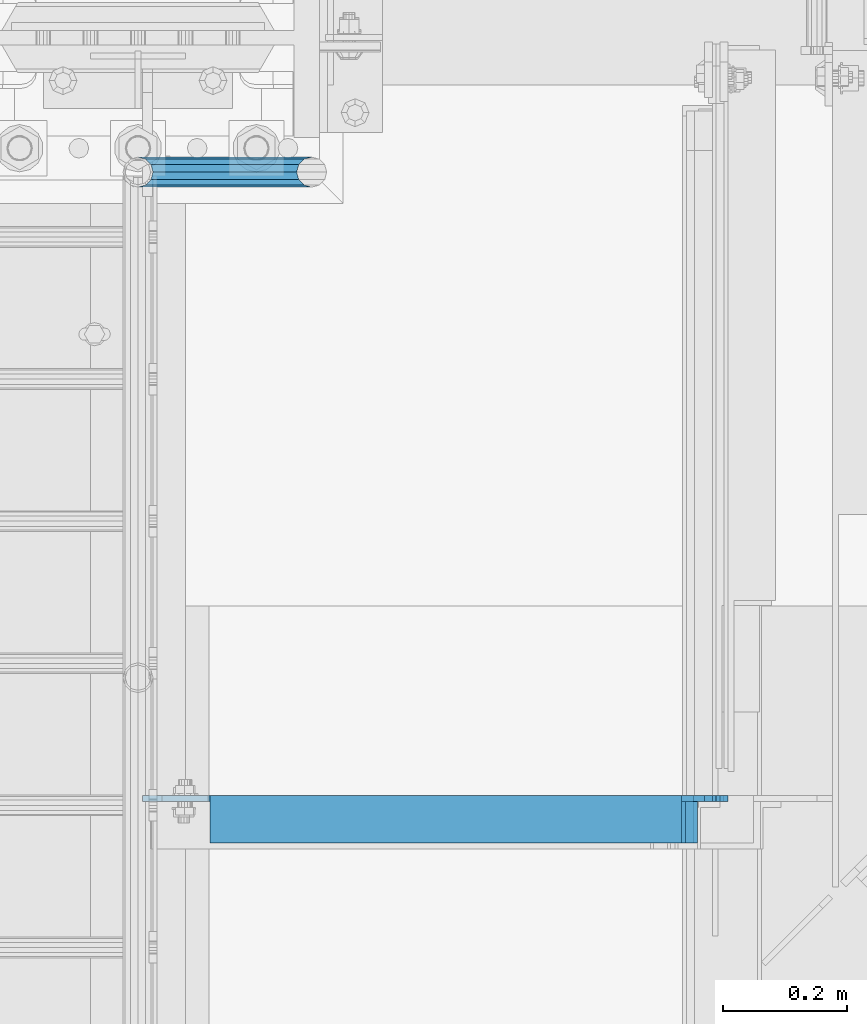
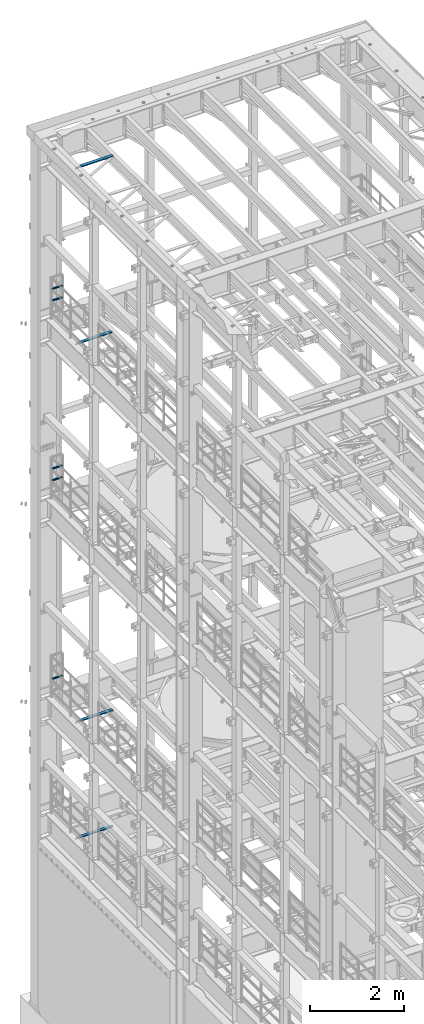
# One storey, part 1313 of 1876: 9 beams, 7 elements without a shape of their own.
"""IFC2X3 building model written with IfcOpenShell, lengths in millimetres."""

from ifc_helpers import new_model, si_unit, frame, origin_with_axes, place, context, subcontext, project, spatial, faceted_brep, material, type_object, element, aggregate, save


model = new_model("IFC2X3")

# Units and contexts
model_context = context("Model", 3, precision=1e-05, world=origin_with_axes())
body_context = subcontext(model_context, "Body", "Model", "MODEL_VIEW")
ifc_project = project(units=[si_unit("LENGTHUNIT", "METRE", prefix="MILLI"), si_unit("AREAUNIT", "SQUARE_METRE"), si_unit("VOLUMEUNIT", "CUBIC_METRE"), si_unit("MASSUNIT", "GRAM", prefix="KILO"), si_unit("TIMEUNIT", "SECOND"), si_unit("PLANEANGLEUNIT", "RADIAN"), si_unit("SOLIDANGLEUNIT", "STERADIAN"), si_unit("THERMODYNAMICTEMPERATUREUNIT", "DEGREE_CELSIUS"), si_unit("LUMINOUSINTENSITYUNIT", "LUMEN")], contexts=[model_context])

# Site, building, storey
site_placement = place(None, origin_with_axes())
site = spatial("IfcSite", under=ifc_project, at=site_placement, CompositionType="ELEMENT")
building_placement = place(site_placement, origin_with_axes())
building = spatial("IfcBuilding", under=site, at=building_placement, Name="Undefined", CompositionType="ELEMENT")
storey_placement = place(building_placement, origin_with_axes())
storey = spatial("IfcBuildingStorey", under=building, at=storey_placement, Name="Undefined", CompositionType="ELEMENT", Elevation=0.0)

# Assembly, beams
assembly_1_placement = place(storey_placement, origin_with_axes())
assembly_1 = element("IfcElementAssembly", 1, at=assembly_1_placement, inside=storey, Name="RAIL", AssemblyPlace="NOTDEFINED", PredefinedType="RIGID_FRAME")
ifc_material_1 = material()
beam_type_1 = type_object("IfcBeamType", Name="PIPE1-1/2SCH40", PredefinedType="NOTDEFINED")
beam_1_placement = place(assembly_1_placement, frame((-8.18545231595635e-12, 13499.7063, 18449.925000036), z_axis=(0.0, 0.0, 1.0), x_axis=(1.0, 0.0, 0.0)))
beam_1 = element("IfcBeam", 2, at=beam_1_placement, type_object=beam_type_1, material=ifc_material_1, Name="RAIL", ObjectType="PIPE1-1/2SCH40", context=body_context, shape_type="Brep", body=[
    faceted_brep([(258.502800903171, -12.0650000000005, 20.8971929933177), (258.502800903171, -12.0650000000005, 15.8661214311796), (258.009372465309, -10.2235000000001, 17.7076214311819), (255.26999389649, 0.0, 20.4470000000001), (255.26999389649, 0.0, 24.130000000001), (258.009372465309, 10.2235000000001, 17.7076214311819), (258.502800903171, 12.0650000000005, 15.8661214311796), (258.502800903171, 12.0650000000005, 20.8971929933177), (279.399993896489, 24.1299999999992, 0.0), (267.33499389649, 20.8971929933177, 12.0649999999987), (267.33499389649, 20.8971929933177, -12.0649999999987), (264.145422334351, 17.7076214311801, 10.2235000000001), (266.884800903171, 20.4470000000001, 0.0), (264.145422334351, 17.7076214311801, -10.2235000000001), (258.502800903171, 12.0650000000005, -15.8661214311796), (258.502800903171, 12.0650000000005, -20.8971929933177), (258.009372465309, 10.2235000000001, -17.7076214311819), (255.26999389649, 0.0, -20.4470000000001), (255.26999389649, 0.0, -24.130000000001), (258.502800903171, -12.0650000000005, -15.8661214311796), (258.502800903171, -12.0650000000005, -20.8971929933177), (258.009372465309, -10.2235000000001, -17.7076214311819), (279.399993896489, -24.1299999999992, 0.0), (267.33499389649, -20.8971929933177, -12.0649999999987), (267.33499389649, -20.8971929933177, 12.0649999999987), (264.145422334351, -17.7076214311801, -10.2235000000001), (266.884800903171, -20.4470000000001, 0.0), (264.145422334351, -17.7076214311801, 10.2235000000001), (12.0650000000064, -20.8971929933177, -12.0649999999987), (20.8971929933249, -12.0650000000005, -20.8971929933177), (0.0, 24.1299999999992, 0.0), (12.0650000000064, 20.8971929933177, -12.0649999999987), (12.0650000000064, 20.8971929933177, 12.0649999999987), (20.8971929933249, 12.0650000000005, 20.8971929933177), (24.1300000000064, 0.0, 24.130000000001), (20.8971929933249, 12.0650000000005, -20.8971929933177), (24.1300000000063, 0.0, -24.130000000001), (24.1300000000063, 0.0, -20.4470000000001), (20.8971929933249, -12.0650000000005, -15.8661214311796), (21.3906214311868, -10.2235000000001, -17.7076214311819), (21.3906214311868, 10.2235000000001, -17.7076214311819), (20.8971929933249, 12.0650000000005, -15.8661214311796), (15.2545715621445, 17.7076214311801, -10.2235000000001), (12.5151929933249, 20.4470000000001, 0.0), (15.2545715621445, 17.7076214311801, 10.2235000000001), (20.8971929933249, 12.0650000000005, 15.8661214311796), (21.3906214311868, 10.2235000000001, 17.7076214311819), (24.1300000000064, 0.0, 20.4470000000001), (21.3906214311868, -10.2235000000001, 17.7076214311819), (20.8971929933249, -12.0650000000005, 15.8661214311796), (20.8971929933249, -12.0650000000005, 20.8971929933177), (12.0650000000064, -20.8971929933177, 12.0649999999987), (0.0, -24.1299999999992, 0.0), (15.2545715621445, -17.7076214311801, 10.2235000000001), (12.5151929933249, -20.4470000000001, 0.0), (15.2545715621445, -17.7076214311801, -10.2235000000001)], [[[0, 1, 2, 3, 4]], [[4, 3, 5, 6, 7]], [[8, 9, 10]], [[7, 6, 11, 12, 13, 14, 15, 10, 9]], [[16, 17, 18, 15, 14]], [[19, 20, 18, 17, 21]], [[22, 23, 24]], [[24, 23, 20, 19, 25, 26, 27, 1, 0]], [[28, 29, 20, 23]], [[30, 31, 32]], [[33, 34, 4, 7]], [[32, 33, 7, 9]], [[30, 32, 9, 8]], [[31, 30, 8, 10]], [[35, 31, 10, 15]], [[36, 35, 15, 18]], [[29, 36, 18, 20]], [[37, 36, 29, 38, 39]], [[40, 41, 35, 36, 37]], [[32, 31, 35, 41, 42, 43, 44, 45, 33]], [[33, 45, 46, 47, 34]], [[34, 47, 48, 49, 50]], [[34, 50, 0, 4]], [[50, 51, 24, 0]], [[51, 52, 22, 24]], [[52, 28, 23, 22]], [[51, 28, 52]], [[50, 49, 53, 54, 55, 38, 29, 28, 51]], [[55, 54, 26, 25]], [[21, 39, 38, 55, 25, 19]], [[37, 39, 21, 17]], [[40, 37, 17, 16]], [[42, 41, 40, 16, 14, 13]], [[43, 42, 13, 12]], [[44, 43, 12, 11]], [[5, 46, 45, 44, 11, 6]], [[47, 46, 5, 3]], [[48, 47, 3, 2]], [[53, 49, 48, 2, 1, 27]], [[54, 53, 27, 26]]]),
])
beam_2_placement = place(assembly_1_placement, frame((-8.18545231595635e-12, 13499.7063, 18754.7250000359), z_axis=(0.0, 0.0, 1.0), x_axis=(1.0, 0.0, 0.0)))
beam_2 = element("IfcBeam", 3, at=beam_2_placement, type_object=beam_type_1, material=ifc_material_1, Name="RAIL", ObjectType="PIPE1-1/2SCH40", context=body_context, shape_type="Brep", body=[
    faceted_brep([(258.502800903171, -12.0650000000005, 20.8971929933177), (258.502800903171, -12.0650000000005, 15.8661214311796), (258.009372465309, -10.2235000000001, 17.7076214311819), (255.26999389649, 0.0, 20.4470000000001), (255.26999389649, 0.0, 24.130000000001), (258.009372465309, 10.2235000000001, 17.7076214311819), (258.502800903171, 12.0650000000005, 15.8661214311796), (258.502800903171, 12.0650000000005, 20.8971929933177), (279.399993896489, 24.1299999999992, 0.0), (267.33499389649, 20.8971929933177, 12.0649999999987), (267.33499389649, 20.8971929933177, -12.0649999999987), (264.145422334351, 17.7076214311801, 10.2235000000001), (266.884800903171, 20.4470000000001, 0.0), (264.145422334351, 17.7076214311801, -10.2235000000001), (258.502800903171, 12.0650000000005, -15.8661214311796), (258.502800903171, 12.0650000000005, -20.8971929933177), (258.009372465309, 10.2235000000001, -17.7076214311819), (255.26999389649, 0.0, -20.4470000000001), (255.26999389649, 0.0, -24.130000000001), (258.502800903171, -12.0650000000005, -15.8661214311796), (258.502800903171, -12.0650000000005, -20.8971929933177), (258.009372465309, -10.2235000000001, -17.7076214311819), (279.399993896489, -24.1299999999992, 0.0), (267.33499389649, -20.8971929933177, -12.0649999999987), (267.33499389649, -20.8971929933177, 12.0649999999987), (264.145422334351, -17.7076214311801, -10.2235000000001), (266.884800903171, -20.4470000000001, 0.0), (264.145422334351, -17.7076214311801, 10.2235000000001), (12.0650000000064, -20.8971929933177, -12.0649999999987), (20.8971929933249, -12.0650000000005, -20.8971929933177), (0.0, 24.1299999999992, 0.0), (12.0650000000064, 20.8971929933177, -12.0649999999987), (12.0650000000064, 20.8971929933177, 12.0649999999987), (20.8971929933249, 12.0650000000005, 20.8971929933177), (24.1300000000064, 0.0, 24.130000000001), (20.8971929933249, 12.0650000000005, -20.8971929933177), (24.1300000000063, 0.0, -24.130000000001), (24.1300000000063, 0.0, -20.4470000000001), (20.8971929933249, -12.0650000000005, -15.8661214311796), (21.3906214311868, -10.2235000000001, -17.7076214311819), (21.3906214311868, 10.2235000000001, -17.7076214311819), (20.8971929933249, 12.0650000000005, -15.8661214311796), (15.2545715621445, 17.7076214311801, -10.2235000000001), (12.5151929933249, 20.4470000000001, 0.0), (15.2545715621445, 17.7076214311801, 10.2235000000001), (20.8971929933249, 12.0650000000005, 15.8661214311796), (21.3906214311868, 10.2235000000001, 17.7076214311819), (24.1300000000064, 0.0, 20.4470000000001), (21.3906214311868, -10.2235000000001, 17.7076214311819), (20.8971929933249, -12.0650000000005, 15.8661214311796), (20.8971929933249, -12.0650000000005, 20.8971929933177), (12.0650000000064, -20.8971929933177, 12.0649999999987), (0.0, -24.1299999999992, 0.0), (15.2545715621445, -17.7076214311801, 10.2235000000001), (12.5151929933249, -20.4470000000001, 0.0), (15.2545715621445, -17.7076214311801, -10.2235000000001)], [[[0, 1, 2, 3, 4]], [[4, 3, 5, 6, 7]], [[8, 9, 10]], [[7, 6, 11, 12, 13, 14, 15, 10, 9]], [[16, 17, 18, 15, 14]], [[19, 20, 18, 17, 21]], [[22, 23, 24]], [[24, 23, 20, 19, 25, 26, 27, 1, 0]], [[28, 29, 20, 23]], [[30, 31, 32]], [[33, 34, 4, 7]], [[32, 33, 7, 9]], [[30, 32, 9, 8]], [[31, 30, 8, 10]], [[35, 31, 10, 15]], [[36, 35, 15, 18]], [[29, 36, 18, 20]], [[37, 36, 29, 38, 39]], [[40, 41, 35, 36, 37]], [[32, 31, 35, 41, 42, 43, 44, 45, 33]], [[33, 45, 46, 47, 34]], [[34, 47, 48, 49, 50]], [[34, 50, 0, 4]], [[50, 51, 24, 0]], [[51, 52, 22, 24]], [[52, 28, 23, 22]], [[51, 28, 52]], [[50, 49, 53, 54, 55, 38, 29, 28, 51]], [[55, 54, 26, 25]], [[21, 39, 38, 55, 25, 19]], [[37, 39, 21, 17]], [[40, 37, 17, 16]], [[42, 41, 40, 16, 14, 13]], [[43, 42, 13, 12]], [[44, 43, 12, 11]], [[5, 46, 45, 44, 11, 6]], [[47, 46, 5, 3]], [[48, 47, 3, 2]], [[53, 49, 48, 2, 1, 27]], [[54, 53, 27, 26]]]),
])
aggregate(assembly_1, [beam_1, beam_2])

assembly_2_placement = place(storey_placement, origin_with_axes())
assembly_2 = element("IfcElementAssembly", 4, at=assembly_2_placement, inside=storey, Name="RAIL", AssemblyPlace="NOTDEFINED", PredefinedType="RIGID_FRAME")
beam_3_placement = place(assembly_2_placement, frame((-8.18545231595635e-12, 13499.7063, 13776.325000036), z_axis=(0.0, 0.0, 1.0), x_axis=(1.0, 0.0, 0.0)))
beam_3 = element("IfcBeam", 5, at=beam_3_placement, type_object=beam_type_1, material=ifc_material_1, Name="RAIL", ObjectType="PIPE1-1/2SCH40", context=body_context, shape_type="Brep", body=[
    faceted_brep([(258.502800903171, -12.0650000000005, 20.8971929933177), (258.502800903171, -12.0650000000005, 15.8661214311796), (258.009372465309, -10.2235000000001, 17.7076214311819), (255.26999389649, 0.0, 20.4470000000001), (255.26999389649, 0.0, 24.130000000001), (258.009372465309, 10.2235000000001, 17.7076214311819), (258.502800903171, 12.0650000000005, 15.8661214311796), (258.502800903171, 12.0650000000005, 20.8971929933177), (279.399993896489, 24.1299999999992, 0.0), (267.33499389649, 20.8971929933177, 12.0649999999987), (267.33499389649, 20.8971929933177, -12.0649999999987), (264.145422334351, 17.7076214311801, 10.2235000000001), (266.884800903171, 20.4470000000001, 0.0), (264.145422334351, 17.7076214311801, -10.2235000000001), (258.502800903171, 12.0650000000005, -15.8661214311796), (258.502800903171, 12.0650000000005, -20.8971929933177), (258.009372465309, 10.2235000000001, -17.7076214311819), (255.26999389649, 0.0, -20.4470000000001), (255.26999389649, 0.0, -24.130000000001), (258.502800903171, -12.0650000000005, -15.8661214311796), (258.502800903171, -12.0650000000005, -20.8971929933177), (258.009372465309, -10.2235000000001, -17.7076214311819), (279.399993896489, -24.1299999999992, 0.0), (267.33499389649, -20.8971929933177, -12.0649999999987), (267.33499389649, -20.8971929933177, 12.0649999999987), (264.145422334351, -17.7076214311801, -10.2235000000001), (266.884800903171, -20.4470000000001, 0.0), (264.145422334351, -17.7076214311801, 10.2235000000001), (12.0650000000064, -20.8971929933177, -12.0649999999987), (20.8971929933249, -12.0650000000005, -20.8971929933177), (0.0, 24.1299999999992, 0.0), (12.0650000000064, 20.8971929933177, -12.0649999999987), (12.0650000000064, 20.8971929933177, 12.0649999999987), (20.8971929933249, 12.0650000000005, 20.8971929933177), (24.1300000000064, 0.0, 24.130000000001), (20.8971929933249, 12.0650000000005, -20.8971929933177), (24.1300000000063, 0.0, -24.130000000001), (24.1300000000063, 0.0, -20.4470000000001), (20.8971929933249, -12.0650000000005, -15.8661214311796), (21.3906214311868, -10.2235000000001, -17.7076214311819), (21.3906214311868, 10.2235000000001, -17.7076214311819), (20.8971929933249, 12.0650000000005, -15.8661214311796), (15.2545715621445, 17.7076214311801, -10.2235000000001), (12.5151929933249, 20.4470000000001, 0.0), (15.2545715621445, 17.7076214311801, 10.2235000000001), (20.8971929933249, 12.0650000000005, 15.8661214311796), (21.3906214311868, 10.2235000000001, 17.7076214311819), (24.1300000000064, 0.0, 20.4470000000001), (21.3906214311868, -10.2235000000001, 17.7076214311819), (20.8971929933249, -12.0650000000005, 15.8661214311796), (20.8971929933249, -12.0650000000005, 20.8971929933177), (12.0650000000064, -20.8971929933177, 12.0649999999987), (0.0, -24.1299999999992, 0.0), (15.2545715621445, -17.7076214311801, 10.2235000000001), (12.5151929933249, -20.4470000000001, 0.0), (15.2545715621445, -17.7076214311801, -10.2235000000001)], [[[0, 1, 2, 3, 4]], [[4, 3, 5, 6, 7]], [[8, 9, 10]], [[7, 6, 11, 12, 13, 14, 15, 10, 9]], [[16, 17, 18, 15, 14]], [[19, 20, 18, 17, 21]], [[22, 23, 24]], [[24, 23, 20, 19, 25, 26, 27, 1, 0]], [[28, 29, 20, 23]], [[30, 31, 32]], [[33, 34, 4, 7]], [[32, 33, 7, 9]], [[30, 32, 9, 8]], [[31, 30, 8, 10]], [[35, 31, 10, 15]], [[36, 35, 15, 18]], [[29, 36, 18, 20]], [[37, 36, 29, 38, 39]], [[40, 41, 35, 36, 37]], [[32, 31, 35, 41, 42, 43, 44, 45, 33]], [[33, 45, 46, 47, 34]], [[34, 47, 48, 49, 50]], [[34, 50, 0, 4]], [[50, 51, 24, 0]], [[51, 52, 22, 24]], [[52, 28, 23, 22]], [[51, 28, 52]], [[50, 49, 53, 54, 55, 38, 29, 28, 51]], [[55, 54, 26, 25]], [[21, 39, 38, 55, 25, 19]], [[37, 39, 21, 17]], [[40, 37, 17, 16]], [[42, 41, 40, 16, 14, 13]], [[43, 42, 13, 12]], [[44, 43, 12, 11]], [[5, 46, 45, 44, 11, 6]], [[47, 46, 5, 3]], [[48, 47, 3, 2]], [[53, 49, 48, 2, 1, 27]], [[54, 53, 27, 26]]]),
])
beam_4_placement = place(assembly_2_placement, frame((-8.18545231595635e-12, 13499.7063, 14081.1250000359), z_axis=(0.0, 0.0, 1.0), x_axis=(1.0, 0.0, 0.0)))
beam_4 = element("IfcBeam", 6, at=beam_4_placement, type_object=beam_type_1, material=ifc_material_1, Name="RAIL", ObjectType="PIPE1-1/2SCH40", context=body_context, shape_type="Brep", body=[
    faceted_brep([(258.502800903171, -12.0650000000005, 20.8971929933177), (258.502800903171, -12.0650000000005, 15.8661214311796), (258.009372465309, -10.2235000000001, 17.7076214311819), (255.26999389649, 0.0, 20.4470000000001), (255.26999389649, 0.0, 24.130000000001), (258.009372465309, 10.2235000000001, 17.7076214311819), (258.502800903171, 12.0650000000005, 15.8661214311796), (258.502800903171, 12.0650000000005, 20.8971929933177), (279.399993896489, 24.1299999999992, 0.0), (267.33499389649, 20.8971929933177, 12.0649999999987), (267.33499389649, 20.8971929933177, -12.0649999999987), (264.145422334351, 17.7076214311801, 10.2235000000001), (266.884800903171, 20.4470000000001, 0.0), (264.145422334351, 17.7076214311801, -10.2235000000001), (258.502800903171, 12.0650000000005, -15.8661214311796), (258.502800903171, 12.0650000000005, -20.8971929933177), (258.009372465309, 10.2235000000001, -17.7076214311819), (255.26999389649, 0.0, -20.4470000000001), (255.26999389649, 0.0, -24.130000000001), (258.502800903171, -12.0650000000005, -15.8661214311796), (258.502800903171, -12.0650000000005, -20.8971929933177), (258.009372465309, -10.2235000000001, -17.7076214311819), (279.399993896489, -24.1299999999992, 0.0), (267.33499389649, -20.8971929933177, -12.0649999999987), (267.33499389649, -20.8971929933177, 12.0649999999987), (264.145422334351, -17.7076214311801, -10.2235000000001), (266.884800903171, -20.4470000000001, 0.0), (264.145422334351, -17.7076214311801, 10.2235000000001), (12.0650000000064, -20.8971929933177, -12.0649999999987), (20.8971929933249, -12.0650000000005, -20.8971929933177), (0.0, 24.1299999999992, 0.0), (12.0650000000064, 20.8971929933177, -12.0649999999987), (12.0650000000064, 20.8971929933177, 12.0649999999987), (20.8971929933249, 12.0650000000005, 20.8971929933177), (24.1300000000064, 0.0, 24.130000000001), (20.8971929933249, 12.0650000000005, -20.8971929933177), (24.1300000000063, 0.0, -24.130000000001), (24.1300000000063, 0.0, -20.4470000000001), (20.8971929933249, -12.0650000000005, -15.8661214311796), (21.3906214311868, -10.2235000000001, -17.7076214311819), (21.3906214311868, 10.2235000000001, -17.7076214311819), (20.8971929933249, 12.0650000000005, -15.8661214311796), (15.2545715621445, 17.7076214311801, -10.2235000000001), (12.5151929933249, 20.4470000000001, 0.0), (15.2545715621445, 17.7076214311801, 10.2235000000001), (20.8971929933249, 12.0650000000005, 15.8661214311796), (21.3906214311868, 10.2235000000001, 17.7076214311819), (24.1300000000064, 0.0, 20.4470000000001), (21.3906214311868, -10.2235000000001, 17.7076214311819), (20.8971929933249, -12.0650000000005, 15.8661214311796), (20.8971929933249, -12.0650000000005, 20.8971929933177), (12.0650000000064, -20.8971929933177, 12.0649999999987), (0.0, -24.1299999999992, 0.0), (15.2545715621445, -17.7076214311801, 10.2235000000001), (12.5151929933249, -20.4470000000001, 0.0), (15.2545715621445, -17.7076214311801, -10.2235000000001)], [[[0, 1, 2, 3, 4]], [[4, 3, 5, 6, 7]], [[8, 9, 10]], [[7, 6, 11, 12, 13, 14, 15, 10, 9]], [[16, 17, 18, 15, 14]], [[19, 20, 18, 17, 21]], [[22, 23, 24]], [[24, 23, 20, 19, 25, 26, 27, 1, 0]], [[28, 29, 20, 23]], [[30, 31, 32]], [[33, 34, 4, 7]], [[32, 33, 7, 9]], [[30, 32, 9, 8]], [[31, 30, 8, 10]], [[35, 31, 10, 15]], [[36, 35, 15, 18]], [[29, 36, 18, 20]], [[37, 36, 29, 38, 39]], [[40, 41, 35, 36, 37]], [[32, 31, 35, 41, 42, 43, 44, 45, 33]], [[33, 45, 46, 47, 34]], [[34, 47, 48, 49, 50]], [[34, 50, 0, 4]], [[50, 51, 24, 0]], [[51, 52, 22, 24]], [[52, 28, 23, 22]], [[51, 28, 52]], [[50, 49, 53, 54, 55, 38, 29, 28, 51]], [[55, 54, 26, 25]], [[21, 39, 38, 55, 25, 19]], [[37, 39, 21, 17]], [[40, 37, 17, 16]], [[42, 41, 40, 16, 14, 13]], [[43, 42, 13, 12]], [[44, 43, 12, 11]], [[5, 46, 45, 44, 11, 6]], [[47, 46, 5, 3]], [[48, 47, 3, 2]], [[53, 49, 48, 2, 1, 27]], [[54, 53, 27, 26]]]),
])
aggregate(assembly_2, [beam_3, beam_4])

# Assembly, beam
assembly_3_placement = place(storey_placement, origin_with_axes())
assembly_3 = element("IfcElementAssembly", 7, at=assembly_3_placement, inside=storey, Name="RAIL", AssemblyPlace="NOTDEFINED", PredefinedType="RIGID_FRAME")
beam_5_placement = place(assembly_3_placement, frame((-8.18545231595635e-12, 13499.7063, 8620.125000036), z_axis=(0.0, 0.0, 1.0), x_axis=(1.0, 0.0, 0.0)))
beam_5 = element("IfcBeam", 8, at=beam_5_placement, type_object=beam_type_1, material=ifc_material_1, Name="RAIL", ObjectType="PIPE1-1/2SCH40", context=body_context, shape_type="Brep", body=[
    faceted_brep([(258.502800903171, -12.0650000000005, 20.8971929933177), (258.502800903171, -12.0650000000005, 15.8661214311796), (258.009372465309, -10.2235000000001, 17.7076214311819), (255.26999389649, 0.0, 20.4470000000001), (255.26999389649, 0.0, 24.130000000001), (258.009372465309, 10.2235000000001, 17.7076214311819), (258.502800903171, 12.0650000000005, 15.8661214311796), (258.502800903171, 12.0650000000005, 20.8971929933177), (279.399993896489, 24.1299999999992, 0.0), (267.33499389649, 20.8971929933177, 12.0649999999987), (267.33499389649, 20.8971929933177, -12.0649999999987), (264.145422334351, 17.7076214311801, 10.2235000000001), (266.884800903171, 20.4470000000001, 0.0), (264.145422334351, 17.7076214311801, -10.2235000000001), (258.502800903171, 12.0650000000005, -15.8661214311796), (258.502800903171, 12.0650000000005, -20.8971929933177), (258.009372465309, 10.2235000000001, -17.7076214311819), (255.26999389649, 0.0, -20.4470000000001), (255.26999389649, 0.0, -24.130000000001), (258.502800903171, -12.0650000000005, -15.8661214311796), (258.502800903171, -12.0650000000005, -20.8971929933177), (258.009372465309, -10.2235000000001, -17.7076214311819), (279.399993896489, -24.1299999999992, 0.0), (267.33499389649, -20.8971929933177, -12.0649999999987), (267.33499389649, -20.8971929933177, 12.0649999999987), (264.145422334351, -17.7076214311801, -10.2235000000001), (266.884800903171, -20.4470000000001, 0.0), (264.145422334351, -17.7076214311801, 10.2235000000001), (12.0650000000064, -20.8971929933177, -12.0649999999987), (20.8971929933249, -12.0650000000005, -20.8971929933177), (0.0, 24.1299999999992, 0.0), (12.0650000000064, 20.8971929933177, -12.0649999999987), (12.0650000000064, 20.8971929933177, 12.0649999999987), (20.8971929933249, 12.0650000000005, 20.8971929933177), (24.1300000000064, 0.0, 24.130000000001), (20.8971929933249, 12.0650000000005, -20.8971929933177), (24.1300000000063, 0.0, -24.130000000001), (24.1300000000063, 0.0, -20.4470000000001), (20.8971929933249, -12.0650000000005, -15.8661214311796), (21.3906214311868, -10.2235000000001, -17.7076214311819), (21.3906214311868, 10.2235000000001, -17.7076214311819), (20.8971929933249, 12.0650000000005, -15.8661214311796), (15.2545715621445, 17.7076214311801, -10.2235000000001), (12.5151929933249, 20.4470000000001, 0.0), (15.2545715621445, 17.7076214311801, 10.2235000000001), (20.8971929933249, 12.0650000000005, 15.8661214311796), (21.3906214311868, 10.2235000000001, 17.7076214311819), (24.1300000000064, 0.0, 20.4470000000001), (21.3906214311868, -10.2235000000001, 17.7076214311819), (20.8971929933249, -12.0650000000005, 15.8661214311796), (20.8971929933249, -12.0650000000005, 20.8971929933177), (12.0650000000064, -20.8971929933177, 12.0649999999987), (0.0, -24.1299999999992, 0.0), (15.2545715621445, -17.7076214311801, 10.2235000000001), (12.5151929933249, -20.4470000000001, 0.0), (15.2545715621445, -17.7076214311801, -10.2235000000001)], [[[0, 1, 2, 3, 4]], [[4, 3, 5, 6, 7]], [[8, 9, 10]], [[7, 6, 11, 12, 13, 14, 15, 10, 9]], [[16, 17, 18, 15, 14]], [[19, 20, 18, 17, 21]], [[22, 23, 24]], [[24, 23, 20, 19, 25, 26, 27, 1, 0]], [[28, 29, 20, 23]], [[30, 31, 32]], [[33, 34, 4, 7]], [[32, 33, 7, 9]], [[30, 32, 9, 8]], [[31, 30, 8, 10]], [[35, 31, 10, 15]], [[36, 35, 15, 18]], [[29, 36, 18, 20]], [[37, 36, 29, 38, 39]], [[40, 41, 35, 36, 37]], [[32, 31, 35, 41, 42, 43, 44, 45, 33]], [[33, 45, 46, 47, 34]], [[34, 47, 48, 49, 50]], [[34, 50, 0, 4]], [[50, 51, 24, 0]], [[51, 52, 22, 24]], [[52, 28, 23, 22]], [[51, 28, 52]], [[50, 49, 53, 54, 55, 38, 29, 28, 51]], [[55, 54, 26, 25]], [[21, 39, 38, 55, 25, 19]], [[37, 39, 21, 17]], [[40, 37, 17, 16]], [[42, 41, 40, 16, 14, 13]], [[43, 42, 13, 12]], [[44, 43, 12, 11]], [[5, 46, 45, 44, 11, 6]], [[47, 46, 5, 3]], [[48, 47, 3, 2]], [[53, 49, 48, 2, 1, 27]], [[54, 53, 27, 26]]]),
])
aggregate(assembly_3, [beam_5])

assembly_4_placement = place(storey_placement, origin_with_axes())
assembly_4 = element("IfcElementAssembly", 9, at=assembly_4_placement, inside=storey, Name="ANGLE", AssemblyPlace="NOTDEFINED", PredefinedType="RIGID_FRAME")
ifc_material_2 = material(Name="STEEL/A36")
beam_type_2 = type_object("IfcBeamType", Name="L3X3X3/8", PredefinedType="NOTDEFINED")
beam_6_placement = place(assembly_4_placement, frame((4.51516825708356e-09, 12458.7, 22517.1), z_axis=(0.0, -1.0, 0.0), x_axis=(1.0, 0.0, 0.0)))
beam_6 = element("IfcBeam", 10, at=beam_6_placement, type_object=beam_type_2, material=ifc_material_2, Name="ANGLE", ObjectType="L3X3X3/8", context=body_context, shape_type="Brep", body=[
    faceted_brep([(115.886999817316, 28.5750000000007, 38.0999999999999), (115.886999817316, 38.0999999999985, 38.0999999999999), (115.886998826692, 38.0999999999985, -38.0999999999999), (115.88699882669, 12.699999237062, -38.0999999999999), (115.886998950515, 12.699999237062, -28.5749999999998), (115.88699895052, 28.5750000000007, -28.5749999999998), (38.8937432114558, 12.699999237062, -38.0999999999999), (38.8937433352807, 12.699999237062, -28.5749999999998), (7.14374321145577, -19.050000762938, -38.0999999999999), (7.14374333528067, -19.050000762938, -28.5749999999998), (7.1437499954859, -38.0999999999985, -38.0999999999999), (7.1437499954859, -38.0999999999985, -28.5749999999998), (949.325002419604, 15.8750003814712, -28.5749999999998), (936.625002610339, 28.5750000000007, -28.5749999999998), (900.113000619098, 28.5750000000007, -28.5749999999998), (949.324999995485, -38.0999999999985, -28.5749999999998), (949.325002419604, 3.17500152588036, -28.5749999999998), (900.11300241932, 28.5750000000007, 38.0999999999999), (900.1130024193, 38.0999999999985, 38.0999999999999), (900.113000361957, 38.0999999999985, -38.0999999999999), (900.113000361924, 28.5750001907363, -38.0999999999999), (936.625002353164, 28.5750001907363, -38.0999999999999), (949.325002162429, 15.8750003814712, -38.0999999999999), (949.325002162429, 3.17500152588036, -38.0999999999999), (949.324999995485, -38.0999999999985, -38.0999999999999)], [[[0, 1, 2, 3, 4, 5]], [[4, 3, 6, 7]], [[7, 6, 8, 9]], [[8, 10, 11, 9]], [[12, 13, 14, 5, 4, 7, 9, 11, 15, 16]], [[0, 5, 14, 17]], [[1, 0, 17, 18]], [[2, 1, 18, 19]], [[17, 14, 20, 19, 18]], [[13, 21, 20, 14]], [[12, 22, 21, 13]], [[16, 23, 22, 12]], [[10, 8, 6, 3, 2, 19, 20, 21, 22, 23, 24]], [[11, 10, 24, 15]], [[23, 16, 15, 24]]]),
])
aggregate(assembly_4, [beam_6])

assembly_5_placement = place(storey_placement, origin_with_axes())
assembly_5 = element("IfcElementAssembly", 11, at=assembly_5_placement, inside=storey, Name="ANGLE", AssemblyPlace="NOTDEFINED", PredefinedType="RIGID_FRAME")
beam_7_placement = place(assembly_5_placement, frame((2.91964701648869e-08, 12458.7, 17945.1), z_axis=(0.0, -1.0, 0.0), x_axis=(1.0, 0.0, 0.0)))
beam_7 = element("IfcBeam", 12, at=beam_7_placement, type_object=beam_type_2, material=ifc_material_2, Name="ANGLE", ObjectType="L3X3X3/8", context=body_context, shape_type="Brep", body=[
    faceted_brep([(115.886999817316, 28.5750000000007, 38.0999999999999), (115.886999817316, 38.0999999999985, 38.0999999999999), (115.886998826692, 38.0999999999985, -38.0999999999999), (115.88699882669, 12.699999237062, -38.0999999999999), (115.886998950515, 12.699999237062, -28.5749999999998), (115.88699895052, 28.5750000000007, -28.5749999999998), (38.8937432114558, 12.699999237062, -38.0999999999999), (38.8937433352807, 12.699999237062, -28.5749999999998), (7.14374321145577, -19.050000762938, -38.0999999999999), (7.14374333528067, -19.050000762938, -28.5749999999998), (7.1437499954859, -38.0999999999985, -38.0999999999999), (7.1437499954859, -38.0999999999985, -28.5749999999998), (923.925002394923, 15.8750003814748, -28.5750000000007), (911.225002585658, 28.5750000000007, -28.5750000000007), (874.713000594384, 28.5750000000007, -28.5750000000007), (923.924999986645, -38.0999999999985, -28.5750000000007), (923.925002394923, 3.175001525884, -28.5750000000007), (874.713002394605, 28.5750000000007, 38.1000000000004), (874.713002394611, 38.0999999999985, 38.1000000000004), (874.713000337267, 38.0999999999985, -38.1000000000004), (874.71300033721, 28.57500019074, -38.1000000000004), (911.225002328483, 28.57500019074, -38.1000000000004), (923.925002137748, 15.8750003814748, -38.1000000000004), (923.925002137748, 3.175001525884, -38.1000000000004), (923.924999986645, -38.0999999999985, -38.1000000000004)], [[[0, 1, 2, 3, 4, 5]], [[4, 3, 6, 7]], [[7, 6, 8, 9]], [[8, 10, 11, 9]], [[12, 13, 14, 5, 4, 7, 9, 11, 15, 16]], [[0, 5, 14, 17]], [[1, 0, 17, 18]], [[2, 1, 18, 19]], [[17, 14, 20, 19, 18]], [[13, 21, 20, 14]], [[12, 22, 21, 13]], [[16, 23, 22, 12]], [[10, 8, 6, 3, 2, 19, 20, 21, 22, 23, 24]], [[11, 10, 24, 15]], [[23, 16, 15, 24]]]),
])
aggregate(assembly_5, [beam_7])

assembly_6_placement = place(storey_placement, origin_with_axes())
assembly_6 = element("IfcElementAssembly", 13, at=assembly_6_placement, inside=storey, Name="ANGLE", AssemblyPlace="NOTDEFINED", PredefinedType="RIGID_FRAME")
beam_8_placement = place(assembly_6_placement, frame((4.54521503245139e-09, 12458.7, 8115.3), z_axis=(0.0, -1.0, 0.0), x_axis=(1.0, 0.0, 0.0)))
beam_8 = element("IfcBeam", 14, at=beam_8_placement, type_object=beam_type_2, material=ifc_material_2, Name="ANGLE", ObjectType="L3X3X3/8", context=body_context, shape_type="Brep", body=[
    faceted_brep([(115.886999817316, 28.5750000000007, 38.0999999999999), (115.886999817316, 38.0999999999985, 38.0999999999999), (115.886998826692, 38.0999999999985, -38.0999999999999), (115.88699882669, 12.699999237062, -38.0999999999999), (115.886998950515, 12.699999237062, -28.5749999999998), (115.88699895052, 28.5750000000007, -28.5749999999998), (38.8937432114558, 12.699999237062, -38.0999999999999), (38.8937433352807, 12.699999237062, -28.5749999999998), (7.14374321145577, -19.050000762938, -38.0999999999999), (7.14374333528067, -19.050000762938, -28.5749999999998), (7.1437499954859, -38.0999999999985, -38.0999999999999), (7.1437499954859, -38.0999999999985, -28.5749999999998), (942.975002419575, 15.8750003814703, -28.5750000000007), (930.27500261031, 28.5749999999998, -28.5750000000007), (893.763000619072, 28.5749999999998, -28.5750000000007), (942.974999995456, -38.1000000000004, -28.5750000000007), (942.975002419575, 3.17500152587945, -28.5750000000007), (893.763002419293, 28.5749999999998, 38.1000000000004), (893.763002419272, 38.1000000000004, 38.1000000000004), (893.763000361928, 38.1000000000004, -38.1000000000004), (893.763000361898, 28.5750001907354, -38.1000000000004), (930.275002353135, 28.5750001907354, -38.1000000000004), (942.9750021624, 15.8750003814703, -38.1000000000004), (942.9750021624, 3.17500152587945, -38.1000000000004), (942.974999995456, -38.1000000000004, -38.1000000000004)], [[[0, 1, 2, 3, 4, 5]], [[4, 3, 6, 7]], [[7, 6, 8, 9]], [[8, 10, 11, 9]], [[12, 13, 14, 5, 4, 7, 9, 11, 15, 16]], [[0, 5, 14, 17]], [[1, 0, 17, 18]], [[2, 1, 18, 19]], [[17, 14, 20, 19, 18]], [[13, 21, 20, 14]], [[12, 22, 21, 13]], [[16, 23, 22, 12]], [[10, 8, 6, 3, 2, 19, 20, 21, 22, 23, 24]], [[11, 10, 24, 15]], [[23, 16, 15, 24]]]),
])
aggregate(assembly_6, [beam_8])

assembly_7_placement = place(storey_placement, origin_with_axes())
assembly_7 = element("IfcElementAssembly", 15, at=assembly_7_placement, inside=storey, Name="ANGLE", AssemblyPlace="NOTDEFINED", PredefinedType="RIGID_FRAME")
beam_9_placement = place(assembly_7_placement, frame((0.0, 12458.7, 5092.7), z_axis=(0.0, -1.0, 0.0), x_axis=(1.0, 0.0, 0.0)))
beam_9 = element("IfcBeam", 16, at=beam_9_placement, type_object=beam_type_2, material=ifc_material_2, Name="ANGLE", ObjectType="L3X3X3/8", context=body_context, shape_type="Brep", body=[
    faceted_brep([(115.886999817316, 28.5750000000007, 38.0999999999999), (115.886999817316, 38.0999999999985, 38.0999999999999), (115.886998826692, 38.0999999999985, -38.0999999999999), (115.88699882669, 12.699999237062, -38.0999999999999), (115.886998950515, 12.699999237062, -28.5749999999998), (115.88699895052, 28.5750000000007, -28.5749999999998), (38.8937432114558, 12.699999237062, -38.0999999999999), (38.8937433352807, 12.699999237062, -28.5749999999998), (7.14374321145577, -19.050000762938, -38.0999999999999), (7.14374333528067, -19.050000762938, -28.5749999999998), (7.1437499954859, -38.0999999999985, -38.0999999999999), (7.1437499954859, -38.0999999999985, -28.5749999999998), (930.275002424124, 15.8750003814703, -28.5750000000007), (917.575002614859, 28.5749999999998, -28.5750000000007), (881.063000623622, 28.5749999999998, -28.5750000000007), (930.274999999999, -38.1000000000004, -28.5750000000007), (930.275002424124, 3.17500152587945, -28.5750000000007), (881.063002423843, 28.5749999999998, 38.1000000000004), (881.063002423821, 38.1000000000004, 38.1000000000004), (881.063000366478, 38.1000000000004, -38.1000000000004), (881.063000366447, 28.5750001907354, -38.1000000000004), (917.575002357685, 28.5750001907354, -38.1000000000004), (930.27500216695, 15.8750003814703, -38.1000000000004), (930.27500216695, 3.17500152587945, -38.1000000000004), (930.274999999999, -38.1000000000004, -38.1000000000004)], [[[0, 1, 2, 3, 4, 5]], [[4, 3, 6, 7]], [[7, 6, 8, 9]], [[8, 10, 11, 9]], [[12, 13, 14, 5, 4, 7, 9, 11, 15, 16]], [[0, 5, 14, 17]], [[1, 0, 17, 18]], [[2, 1, 18, 19]], [[17, 14, 20, 19, 18]], [[13, 21, 20, 14]], [[12, 22, 21, 13]], [[16, 23, 22, 12]], [[10, 8, 6, 3, 2, 19, 20, 21, 22, 23, 24]], [[11, 10, 24, 15]], [[23, 16, 15, 24]]]),
])
aggregate(assembly_7, [beam_9])

save(model, "model.ifc")
